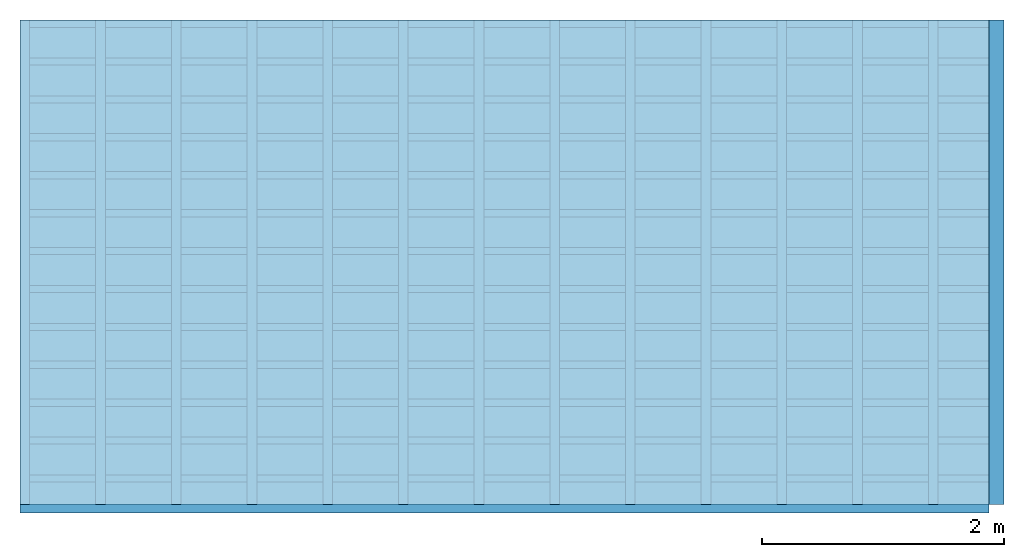
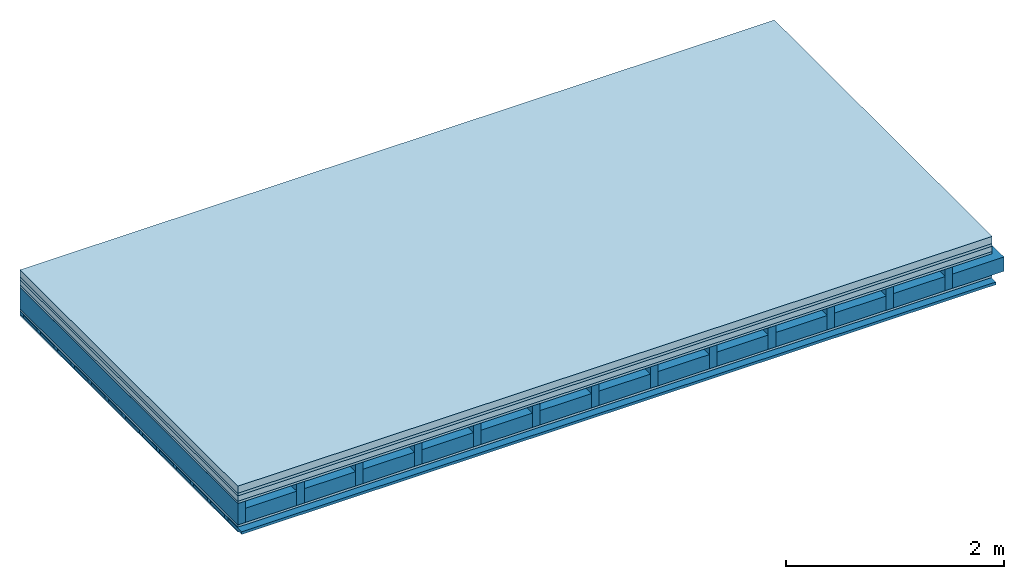
# One storey: 6 plates, 4 members, 1 element without a shape of its own.
"""IFC4 building model written with IfcOpenShell, lengths in metres."""

from ifc_helpers import new_model, si_unit, derived_unit, direction, frame, frame_2d, origin, origin_with_axes, place, context, project, spatial, rectangle, extrude, material, layer, layer_set, type_object, element, aggregate, save


model = new_model("IFC4")

# Units and contexts
plan_context = context("Plan", 3, precision=1e-05, world=origin(), true_north=direction((0.0, 1.0)))
model_context = context("Model", 3, precision=1e-05, world=origin(), true_north=direction((0.0, 1.0)))
ifc_project = project(units=[si_unit("LENGTHUNIT", "METRE"), derived_unit("SOUNDPRESSUREUNIT", [(si_unit("PRESSUREUNIT", "PASCAL", prefix="MICRO"), 0)]), si_unit("ENERGYUNIT", "JOULE", prefix="MEGA"), si_unit("MASSUNIT", "GRAM", prefix="KILO"), derived_unit("THERMALTRANSMITTANCEUNIT", [(si_unit("POWERUNIT", "WATT"), 1), (si_unit("AREAUNIT", "SQUARE_METRE"), -1), (si_unit("THERMODYNAMICTEMPERATUREUNIT", "KELVIN"), -1)]), derived_unit("AREADENSITYUNIT", [(si_unit("MASSUNIT", "GRAM", prefix="KILO"), 1), (si_unit("AREAUNIT", "SQUARE_METRE"), -1)]), derived_unit("USERDEFINED", [(si_unit("ENERGYUNIT", "JOULE", prefix="MEGA"), 1), (si_unit("AREAUNIT", "SQUARE_METRE"), -1)])], contexts=[plan_context, model_context])

# Site, building, storey
site = spatial("IfcSite", under=ifc_project)
building_placement = place(None, origin())
building = spatial("IfcBuilding", under=site, at=building_placement)
storey_placement = place(building_placement, origin())
storey = spatial("IfcBuildingStorey", under=building, at=storey_placement)

# Slab, members, plates
ifc_material_1 = material(Name="Cement screed", Category="04.006")
ifc_layer_1 = layer(ifc_material_1, 0.08, Name="On-material")
ifc_material_2 = material()
ifc_layer_2 = layer(ifc_material_2, 0.03, Name="Impact sound insulation")
ifc_material_3 = material(Name="Cement panels, glued on sub-floor", Category="02.007")
ifc_layer_3 = layer(ifc_material_3, 0.06, Name="on Supporting structure")
ifc_material_4 = material(Category="07.001")
ifc_layer_4 = layer(ifc_material_4, 0.025, Name="Sub-floor")
ifc_material_5 = material(Name="Rigid, of the art")
ifc_layer_5 = layer(ifc_material_5, 0.0, Name="Bond")
ifc_layer_6 = layer(None, 0.24, Name="Supporting structure")
ifc_layer_7 = layer(ifc_material_5, 0.0, Name="Bond")
ifc_layer_8 = layer(ifc_material_4, 0.025, Name="Lower layer 1")
ifc_layer_9 = layer(None, 0.04, Name="Battens / profiles")
ifc_material_6 = material(Category="03.007")
ifc_layer_10 = layer(ifc_material_6, 0.015, Name="Ceiling covering 1st layer")
ifc_material_7 = material(Name="Glued joints")
ifc_layer_11 = layer(ifc_material_7, 0.0, Name="Surface / treatment")
ifc_layer_set = layer_set([ifc_layer_1, ifc_layer_2, ifc_layer_3, ifc_layer_4, ifc_layer_5, ifc_layer_6, ifc_layer_7, ifc_layer_8, ifc_layer_9, ifc_layer_10, ifc_layer_11])
slab_type = type_object("IfcSlabType", Name="A0468", PredefinedType="NOTDEFINED", material=ifc_layer_set)
slab_placement = place(None, frame((0.0, 0.0, 0.0), z_axis=(0.0, 0.0, -1.0), x_axis=(1.0, 0.0, 0.0)))
slab = element("IfcSlab", 1, at=slab_placement, inside=storey, type_object=slab_type, material=ifc_layer_set, Name="Slab #1")
ifc_material_8 = material()
member_1_placement = place(slab_placement, origin())
member_1 = element("IfcMember", 2, at=member_1_placement, material=ifc_material_8, Name="Supporting structure", context=plan_context, shape_type="SweptSolid", body=[
    extrude(rectangle(XDim=0.08, YDim=0.24, at=frame_2d((0.04, 0.12), x_axis=(1.0, 0.0))), frame((0.0, 4.0, 0.195), z_axis=(0.0, -1.0, 0.0), x_axis=(1.0, 0.0, 0.0)), (0.0, 0.0, 1.0), 4.0),
    extrude(rectangle(XDim=0.08, YDim=0.24, at=frame_2d((0.04, 0.12), x_axis=(1.0, 0.0))), frame((0.625, 4.0, 0.195), z_axis=(0.0, -1.0, 0.0), x_axis=(1.0, 0.0, 0.0)), (0.0, 0.0, 1.0), 4.0),
    extrude(rectangle(XDim=0.08, YDim=0.24, at=frame_2d((0.04, 0.12), x_axis=(1.0, 0.0))), frame((1.25, 4.0, 0.195), z_axis=(0.0, -1.0, 0.0), x_axis=(1.0, 0.0, 0.0)), (0.0, 0.0, 1.0), 4.0),
    extrude(rectangle(XDim=0.08, YDim=0.24, at=frame_2d((0.04, 0.12), x_axis=(1.0, 0.0))), frame((1.875, 4.0, 0.195), z_axis=(0.0, -1.0, 0.0), x_axis=(1.0, 0.0, 0.0)), (0.0, 0.0, 1.0), 4.0),
    extrude(rectangle(XDim=0.08, YDim=0.24, at=frame_2d((0.04, 0.12), x_axis=(1.0, 0.0))), frame((2.5, 4.0, 0.195), z_axis=(0.0, -1.0, 0.0), x_axis=(1.0, 0.0, 0.0)), (0.0, 0.0, 1.0), 4.0),
    extrude(rectangle(XDim=0.08, YDim=0.24, at=frame_2d((0.04, 0.12), x_axis=(1.0, 0.0))), frame((3.125, 4.0, 0.195), z_axis=(0.0, -1.0, 0.0), x_axis=(1.0, 0.0, 0.0)), (0.0, 0.0, 1.0), 4.0),
    extrude(rectangle(XDim=0.08, YDim=0.24, at=frame_2d((0.04, 0.12), x_axis=(1.0, 0.0))), frame((3.75, 4.0, 0.195), z_axis=(0.0, -1.0, 0.0), x_axis=(1.0, 0.0, 0.0)), (0.0, 0.0, 1.0), 4.0),
    extrude(rectangle(XDim=0.08, YDim=0.24, at=frame_2d((0.04, 0.12), x_axis=(1.0, 0.0))), frame((4.375, 4.0, 0.195), z_axis=(0.0, -1.0, 0.0), x_axis=(1.0, 0.0, 0.0)), (0.0, 0.0, 1.0), 4.0),
    extrude(rectangle(XDim=0.08, YDim=0.24, at=frame_2d((0.04, 0.12), x_axis=(1.0, 0.0))), frame((5.0, 4.0, 0.195), z_axis=(0.0, -1.0, 0.0), x_axis=(1.0, 0.0, 0.0)), (0.0, 0.0, 1.0), 4.0),
    extrude(rectangle(XDim=0.08, YDim=0.24, at=frame_2d((0.04, 0.12), x_axis=(1.0, 0.0))), frame((5.625, 4.0, 0.195), z_axis=(0.0, -1.0, 0.0), x_axis=(1.0, 0.0, 0.0)), (0.0, 0.0, 1.0), 4.0),
    extrude(rectangle(XDim=0.08, YDim=0.24, at=frame_2d((0.04, 0.12), x_axis=(1.0, 0.0))), frame((6.25, 4.0, 0.195), z_axis=(0.0, -1.0, 0.0), x_axis=(1.0, 0.0, 0.0)), (0.0, 0.0, 1.0), 4.0),
    extrude(rectangle(XDim=0.08, YDim=0.24, at=frame_2d((0.04, 0.12), x_axis=(1.0, 0.0))), frame((6.875, 4.0, 0.195), z_axis=(0.0, -1.0, 0.0), x_axis=(1.0, 0.0, 0.0)), (0.0, 0.0, 1.0), 4.0),
    extrude(rectangle(XDim=0.08, YDim=0.24, at=frame_2d((0.04, 0.12), x_axis=(1.0, 0.0))), frame((7.5, 4.0, 0.195), z_axis=(0.0, -1.0, 0.0), x_axis=(1.0, 0.0, 0.0)), (0.0, 0.0, 1.0), 4.0),
])
ifc_material_9 = material()
member_2_placement = place(slab_placement, origin())
member_2 = element("IfcMember", 3, at=member_2_placement, material=ifc_material_9, Name="Cavity", context=plan_context, shape_type="SweptSolid", body=[
    extrude(rectangle(XDim=0.545, YDim=0.16, at=frame_2d((0.2725, 0.08), x_axis=(1.0, 0.0))), frame((0.08, 4.0, 0.275), z_axis=(0.0, -1.0, 0.0), x_axis=(1.0, 0.0, 0.0)), (0.0, 0.0, 1.0), 4.0),
    extrude(rectangle(XDim=0.545, YDim=0.16, at=frame_2d((0.2725, 0.08), x_axis=(1.0, 0.0))), frame((0.705, 4.0, 0.275), z_axis=(0.0, -1.0, 0.0), x_axis=(1.0, 0.0, 0.0)), (0.0, 0.0, 1.0), 4.0),
    extrude(rectangle(XDim=0.545, YDim=0.16, at=frame_2d((0.2725, 0.08), x_axis=(1.0, 0.0))), frame((1.33, 4.0, 0.275), z_axis=(0.0, -1.0, 0.0), x_axis=(1.0, 0.0, 0.0)), (0.0, 0.0, 1.0), 4.0),
    extrude(rectangle(XDim=0.545, YDim=0.16, at=frame_2d((0.2725, 0.08), x_axis=(1.0, 0.0))), frame((1.955, 4.0, 0.275), z_axis=(0.0, -1.0, 0.0), x_axis=(1.0, 0.0, 0.0)), (0.0, 0.0, 1.0), 4.0),
    extrude(rectangle(XDim=0.545, YDim=0.16, at=frame_2d((0.2725, 0.08), x_axis=(1.0, 0.0))), frame((2.58, 4.0, 0.275), z_axis=(0.0, -1.0, 0.0), x_axis=(1.0, 0.0, 0.0)), (0.0, 0.0, 1.0), 4.0),
    extrude(rectangle(XDim=0.545, YDim=0.16, at=frame_2d((0.2725, 0.08), x_axis=(1.0, 0.0))), frame((3.205, 4.0, 0.275), z_axis=(0.0, -1.0, 0.0), x_axis=(1.0, 0.0, 0.0)), (0.0, 0.0, 1.0), 4.0),
    extrude(rectangle(XDim=0.545, YDim=0.16, at=frame_2d((0.2725, 0.08), x_axis=(1.0, 0.0))), frame((3.83, 4.0, 0.275), z_axis=(0.0, -1.0, 0.0), x_axis=(1.0, 0.0, 0.0)), (0.0, 0.0, 1.0), 4.0),
    extrude(rectangle(XDim=0.545, YDim=0.16, at=frame_2d((0.2725, 0.08), x_axis=(1.0, 0.0))), frame((4.455, 4.0, 0.275), z_axis=(0.0, -1.0, 0.0), x_axis=(1.0, 0.0, 0.0)), (0.0, 0.0, 1.0), 4.0),
    extrude(rectangle(XDim=0.545, YDim=0.16, at=frame_2d((0.2725, 0.08), x_axis=(1.0, 0.0))), frame((5.08, 4.0, 0.275), z_axis=(0.0, -1.0, 0.0), x_axis=(1.0, 0.0, 0.0)), (0.0, 0.0, 1.0), 4.0),
    extrude(rectangle(XDim=0.545, YDim=0.16, at=frame_2d((0.2725, 0.08), x_axis=(1.0, 0.0))), frame((5.705, 4.0, 0.275), z_axis=(0.0, -1.0, 0.0), x_axis=(1.0, 0.0, 0.0)), (0.0, 0.0, 1.0), 4.0),
    extrude(rectangle(XDim=0.545, YDim=0.16, at=frame_2d((0.2725, 0.08), x_axis=(1.0, 0.0))), frame((6.33, 4.0, 0.275), z_axis=(0.0, -1.0, 0.0), x_axis=(1.0, 0.0, 0.0)), (0.0, 0.0, 1.0), 4.0),
    extrude(rectangle(XDim=0.545, YDim=0.16, at=frame_2d((0.2725, 0.08), x_axis=(1.0, 0.0))), frame((6.955, 4.0, 0.275), z_axis=(0.0, -1.0, 0.0), x_axis=(1.0, 0.0, 0.0)), (0.0, 0.0, 1.0), 4.0),
    extrude(rectangle(XDim=0.545, YDim=0.16, at=frame_2d((0.2725, 0.08), x_axis=(1.0, 0.0))), frame((7.58, 4.0, 0.275), z_axis=(0.0, -1.0, 0.0), x_axis=(1.0, 0.0, 0.0)), (0.0, 0.0, 1.0), 4.0),
])
ifc_material_10 = material()
member_3_placement = place(slab_placement, origin())
member_3 = element("IfcMember", 4, at=member_3_placement, material=ifc_material_10, Name="Battens / profiles", context=plan_context, shape_type="SweptSolid", body=[
    extrude(rectangle(XDim=0.06, YDim=0.04, at=frame_2d((0.03, 0.02), x_axis=(1.0, 0.0))), frame((0.0, 0.0, 0.46), z_axis=(1.0, 0.0, 0.0), x_axis=(0.0, 1.0, 0.0)), (0.0, 0.0, 1.0), 8.0),
    extrude(rectangle(XDim=0.06, YDim=0.04, at=frame_2d((0.03, 0.02), x_axis=(1.0, 0.0))), frame((0.0, 0.313, 0.46), z_axis=(1.0, 0.0, 0.0), x_axis=(0.0, 1.0, 0.0)), (0.0, 0.0, 1.0), 8.0),
    extrude(rectangle(XDim=0.06, YDim=0.04, at=frame_2d((0.03, 0.02), x_axis=(1.0, 0.0))), frame((0.0, 0.626, 0.46), z_axis=(1.0, 0.0, 0.0), x_axis=(0.0, 1.0, 0.0)), (0.0, 0.0, 1.0), 8.0),
    extrude(rectangle(XDim=0.06, YDim=0.04, at=frame_2d((0.03, 0.02), x_axis=(1.0, 0.0))), frame((0.0, 0.939, 0.46), z_axis=(1.0, 0.0, 0.0), x_axis=(0.0, 1.0, 0.0)), (0.0, 0.0, 1.0), 8.0),
    extrude(rectangle(XDim=0.06, YDim=0.04, at=frame_2d((0.03, 0.02), x_axis=(1.0, 0.0))), frame((0.0, 1.252, 0.46), z_axis=(1.0, 0.0, 0.0), x_axis=(0.0, 1.0, 0.0)), (0.0, 0.0, 1.0), 8.0),
    extrude(rectangle(XDim=0.06, YDim=0.04, at=frame_2d((0.03, 0.02), x_axis=(1.0, 0.0))), frame((0.0, 1.565, 0.46), z_axis=(1.0, 0.0, 0.0), x_axis=(0.0, 1.0, 0.0)), (0.0, 0.0, 1.0), 8.0),
    extrude(rectangle(XDim=0.06, YDim=0.04, at=frame_2d((0.03, 0.02), x_axis=(1.0, 0.0))), frame((0.0, 1.878, 0.46), z_axis=(1.0, 0.0, 0.0), x_axis=(0.0, 1.0, 0.0)), (0.0, 0.0, 1.0), 8.0),
    extrude(rectangle(XDim=0.06, YDim=0.04, at=frame_2d((0.03, 0.02), x_axis=(1.0, 0.0))), frame((0.0, 2.191, 0.46), z_axis=(1.0, 0.0, 0.0), x_axis=(0.0, 1.0, 0.0)), (0.0, 0.0, 1.0), 8.0),
    extrude(rectangle(XDim=0.06, YDim=0.04, at=frame_2d((0.03, 0.02), x_axis=(1.0, 0.0))), frame((0.0, 2.504, 0.46), z_axis=(1.0, 0.0, 0.0), x_axis=(0.0, 1.0, 0.0)), (0.0, 0.0, 1.0), 8.0),
    extrude(rectangle(XDim=0.06, YDim=0.04, at=frame_2d((0.03, 0.02), x_axis=(1.0, 0.0))), frame((0.0, 2.817, 0.46), z_axis=(1.0, 0.0, 0.0), x_axis=(0.0, 1.0, 0.0)), (0.0, 0.0, 1.0), 8.0),
    extrude(rectangle(XDim=0.06, YDim=0.04, at=frame_2d((0.03, 0.02), x_axis=(1.0, 0.0))), frame((0.0, 3.13, 0.46), z_axis=(1.0, 0.0, 0.0), x_axis=(0.0, 1.0, 0.0)), (0.0, 0.0, 1.0), 8.0),
    extrude(rectangle(XDim=0.06, YDim=0.04, at=frame_2d((0.03, 0.02), x_axis=(1.0, 0.0))), frame((0.0, 3.443, 0.46), z_axis=(1.0, 0.0, 0.0), x_axis=(0.0, 1.0, 0.0)), (0.0, 0.0, 1.0), 8.0),
    extrude(rectangle(XDim=0.06, YDim=0.04, at=frame_2d((0.03, 0.02), x_axis=(1.0, 0.0))), frame((0.0, 3.756, 0.46), z_axis=(1.0, 0.0, 0.0), x_axis=(0.0, 1.0, 0.0)), (0.0, 0.0, 1.0), 8.0),
])
member_4_placement = place(slab_placement, origin())
member_4 = element("IfcMember", 5, at=member_4_placement, material=ifc_material_9, Name="Cavity", context=plan_context, shape_type="SweptSolid", body=[
    extrude(rectangle(XDim=0.253, YDim=0.03, at=frame_2d((0.1265, 0.015), x_axis=(1.0, 0.0))), frame((0.0, 0.06, 0.47), z_axis=(1.0, 0.0, 0.0), x_axis=(0.0, 1.0, 0.0)), (0.0, 0.0, 1.0), 8.0),
    extrude(rectangle(XDim=0.253, YDim=0.03, at=frame_2d((0.1265, 0.015), x_axis=(1.0, 0.0))), frame((0.0, 0.373, 0.47), z_axis=(1.0, 0.0, 0.0), x_axis=(0.0, 1.0, 0.0)), (0.0, 0.0, 1.0), 8.0),
    extrude(rectangle(XDim=0.253, YDim=0.03, at=frame_2d((0.1265, 0.015), x_axis=(1.0, 0.0))), frame((0.0, 0.686, 0.47), z_axis=(1.0, 0.0, 0.0), x_axis=(0.0, 1.0, 0.0)), (0.0, 0.0, 1.0), 8.0),
    extrude(rectangle(XDim=0.253, YDim=0.03, at=frame_2d((0.1265, 0.015), x_axis=(1.0, 0.0))), frame((0.0, 0.999, 0.47), z_axis=(1.0, 0.0, 0.0), x_axis=(0.0, 1.0, 0.0)), (0.0, 0.0, 1.0), 8.0),
    extrude(rectangle(XDim=0.253, YDim=0.03, at=frame_2d((0.1265, 0.015), x_axis=(1.0, 0.0))), frame((0.0, 1.312, 0.47), z_axis=(1.0, 0.0, 0.0), x_axis=(0.0, 1.0, 0.0)), (0.0, 0.0, 1.0), 8.0),
    extrude(rectangle(XDim=0.253, YDim=0.03, at=frame_2d((0.1265, 0.015), x_axis=(1.0, 0.0))), frame((0.0, 1.625, 0.47), z_axis=(1.0, 0.0, 0.0), x_axis=(0.0, 1.0, 0.0)), (0.0, 0.0, 1.0), 8.0),
    extrude(rectangle(XDim=0.253, YDim=0.03, at=frame_2d((0.1265, 0.015), x_axis=(1.0, 0.0))), frame((0.0, 1.938, 0.47), z_axis=(1.0, 0.0, 0.0), x_axis=(0.0, 1.0, 0.0)), (0.0, 0.0, 1.0), 8.0),
    extrude(rectangle(XDim=0.253, YDim=0.03, at=frame_2d((0.1265, 0.015), x_axis=(1.0, 0.0))), frame((0.0, 2.251, 0.47), z_axis=(1.0, 0.0, 0.0), x_axis=(0.0, 1.0, 0.0)), (0.0, 0.0, 1.0), 8.0),
    extrude(rectangle(XDim=0.253, YDim=0.03, at=frame_2d((0.1265, 0.015), x_axis=(1.0, 0.0))), frame((0.0, 2.564, 0.47), z_axis=(1.0, 0.0, 0.0), x_axis=(0.0, 1.0, 0.0)), (0.0, 0.0, 1.0), 8.0),
    extrude(rectangle(XDim=0.253, YDim=0.03, at=frame_2d((0.1265, 0.015), x_axis=(1.0, 0.0))), frame((0.0, 2.877, 0.47), z_axis=(1.0, 0.0, 0.0), x_axis=(0.0, 1.0, 0.0)), (0.0, 0.0, 1.0), 8.0),
    extrude(rectangle(XDim=0.253, YDim=0.03, at=frame_2d((0.1265, 0.015), x_axis=(1.0, 0.0))), frame((0.0, 3.19, 0.47), z_axis=(1.0, 0.0, 0.0), x_axis=(0.0, 1.0, 0.0)), (0.0, 0.0, 1.0), 8.0),
    extrude(rectangle(XDim=0.253, YDim=0.03, at=frame_2d((0.1265, 0.015), x_axis=(1.0, 0.0))), frame((0.0, 3.503, 0.47), z_axis=(1.0, 0.0, 0.0), x_axis=(0.0, 1.0, 0.0)), (0.0, 0.0, 1.0), 8.0),
    extrude(rectangle(XDim=0.253, YDim=0.03, at=frame_2d((0.1265, 0.015), x_axis=(1.0, 0.0))), frame((0.0, 3.816, 0.47), z_axis=(1.0, 0.0, 0.0), x_axis=(0.0, 1.0, 0.0)), (0.0, 0.0, 1.0), 8.0),
])
plate_1_placement = place(slab_placement, origin())
plate_1 = element("IfcPlate", 6, at=plate_1_placement, material=ifc_material_1, Name="On-material", context=plan_context, shape_type="SweptSolid", body=[
    extrude(rectangle(XDim=8.0, YDim=4.0, at=frame_2d((4.0, 2.0), x_axis=(1.0, 0.0))), origin_with_axes(), (0.0, 0.0, 1.0), 0.08),
])
plate_2_placement = place(slab_placement, origin())
plate_2 = element("IfcPlate", 7, at=plate_2_placement, material=ifc_material_2, Name="Impact sound insulation", context=plan_context, shape_type="SweptSolid", body=[
    extrude(rectangle(XDim=8.0, YDim=4.0, at=frame_2d((4.0, 2.0), x_axis=(1.0, 0.0))), frame((0.0, 0.0, 0.08), z_axis=(0.0, 0.0, 1.0), x_axis=(1.0, 0.0, 0.0)), (0.0, 0.0, 1.0), 0.03),
])
plate_3_placement = place(slab_placement, origin())
plate_3 = element("IfcPlate", 8, at=plate_3_placement, material=ifc_material_3, Name="on Supporting structure", context=plan_context, shape_type="SweptSolid", body=[
    extrude(rectangle(XDim=8.0, YDim=4.0, at=frame_2d((4.0, 2.0), x_axis=(1.0, 0.0))), frame((0.0, 0.0, 0.11), z_axis=(0.0, 0.0, 1.0), x_axis=(1.0, 0.0, 0.0)), (0.0, 0.0, 1.0), 0.06),
])
plate_4_placement = place(slab_placement, origin())
plate_4 = element("IfcPlate", 9, at=plate_4_placement, material=ifc_material_4, Name="Sub-floor", context=plan_context, shape_type="SweptSolid", body=[
    extrude(rectangle(XDim=8.0, YDim=4.0, at=frame_2d((4.0, 2.0), x_axis=(1.0, 0.0))), frame((0.0, 0.0, 0.17), z_axis=(0.0, 0.0, 1.0), x_axis=(1.0, 0.0, 0.0)), (0.0, 0.0, 1.0), 0.025),
])
plate_5_placement = place(slab_placement, origin())
plate_5 = element("IfcPlate", 10, at=plate_5_placement, material=ifc_material_4, Name="Lower layer 1", context=plan_context, shape_type="SweptSolid", body=[
    extrude(rectangle(XDim=8.0, YDim=4.0, at=frame_2d((4.0, 2.0), x_axis=(1.0, 0.0))), frame((0.0, 0.0, 0.435), z_axis=(0.0, 0.0, 1.0), x_axis=(1.0, 0.0, 0.0)), (0.0, 0.0, 1.0), 0.025),
])
plate_6_placement = place(slab_placement, origin())
plate_6 = element("IfcPlate", 11, at=plate_6_placement, material=ifc_material_6, Name="Ceiling covering 1st layer", context=plan_context, shape_type="SweptSolid", body=[
    extrude(rectangle(XDim=8.0, YDim=4.0, at=frame_2d((4.0, 2.0), x_axis=(1.0, 0.0))), frame((0.0, 0.0, 0.5), z_axis=(0.0, 0.0, 1.0), x_axis=(1.0, 0.0, 0.0)), (0.0, 0.0, 1.0), 0.015),
])
aggregate(slab, [plate_1, plate_2, plate_3, plate_4, member_1, member_2, plate_5, member_3, member_4, plate_6])

save(model, "model.ifc")
